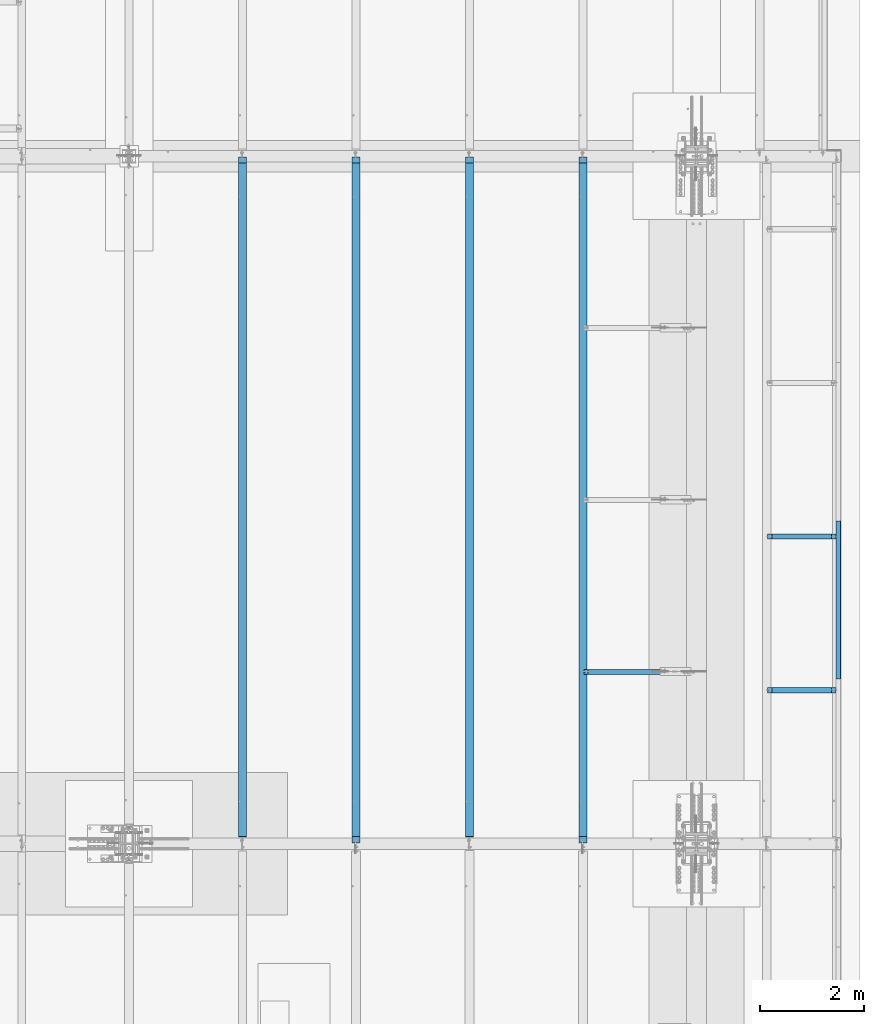
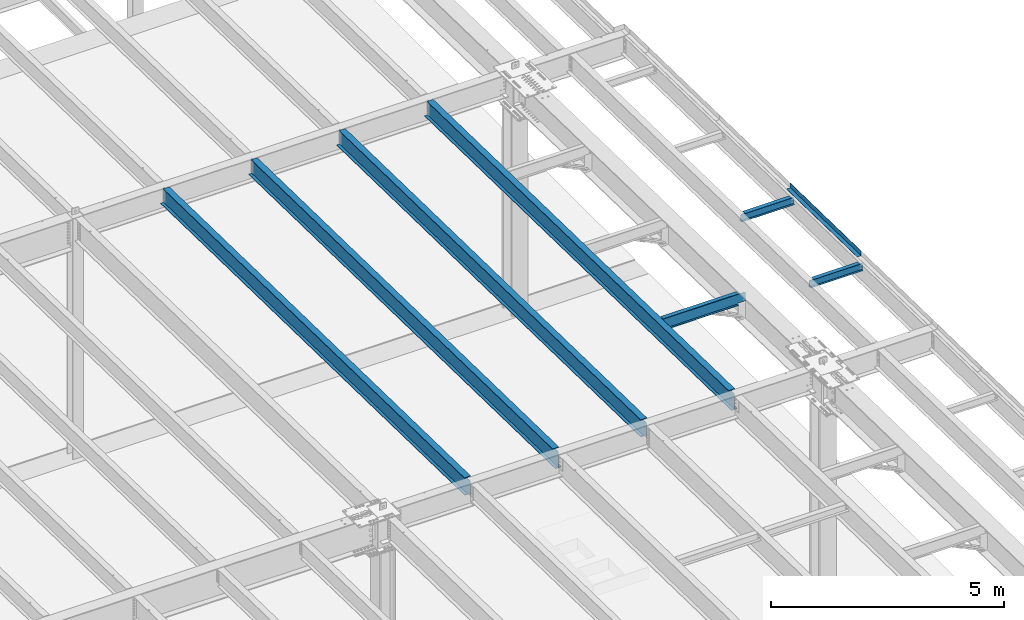
# One storey, part 1115 of 1763: 8 beams, 8 elements without a shape of their own.
"""IFC2X3 building model written with IfcOpenShell, lengths in millimetres."""

from ifc_helpers import new_model, si_unit, frame, origin_with_axes, place, context, subcontext, project, spatial, faceted_brep, material, type_object, element, aggregate, save


model = new_model("IFC2X3")

# Units and contexts
model_context = context("Model", 3, precision=1e-05, world=origin_with_axes())
body_context = subcontext(model_context, "Body", "Model", "MODEL_VIEW")
ifc_project = project(units=[si_unit("LENGTHUNIT", "METRE", prefix="MILLI"), si_unit("AREAUNIT", "SQUARE_METRE"), si_unit("VOLUMEUNIT", "CUBIC_METRE"), si_unit("MASSUNIT", "GRAM", prefix="KILO"), si_unit("TIMEUNIT", "SECOND"), si_unit("PLANEANGLEUNIT", "RADIAN"), si_unit("SOLIDANGLEUNIT", "STERADIAN"), si_unit("THERMODYNAMICTEMPERATUREUNIT", "DEGREE_CELSIUS"), si_unit("LUMINOUSINTENSITYUNIT", "LUMEN")], contexts=[model_context])

# Site, building, storey
site_placement = place(None, origin_with_axes())
site = spatial("IfcSite", under=ifc_project, at=site_placement, CompositionType="ELEMENT")
building_placement = place(site_placement, origin_with_axes())
building = spatial("IfcBuilding", under=site, at=building_placement, Name="Undefined", CompositionType="ELEMENT")
storey_placement = place(building_placement, origin_with_axes())
storey = spatial("IfcBuildingStorey", under=building, at=storey_placement, Name="Undefined", CompositionType="ELEMENT", Elevation=0.0)

# Assembly, beam
assembly_1_placement = place(storey_placement, origin_with_axes())
assembly_1 = element("IfcElementAssembly", 1, at=assembly_1_placement, inside=storey, Name="BEAM", AssemblyPlace="NOTDEFINED", PredefinedType="RIGID_FRAME")
ifc_material_1 = material(Name="STEEL/A36")
beam_type_1 = type_object("IfcBeamType", PredefinedType="NOTDEFINED")
beam_1_placement = place(assembly_1_placement, frame((-21348.1372736983, 5148.90340620207, 11813.4874748856), z_axis=(0.0, -0.999781542838788, 0.0209013539966307), x_axis=(1.0, 0.0, 0.0)))
beam_1 = element("IfcBeam", 2, at=beam_1_placement, type_object=beam_type_1, material=ifc_material_1, Name="BENT_PLATE", context=body_context, shape_type="Brep", body=[
    faceted_brep([(0.0, -3.17499999999927, -1523.99999999999), (0.0, -3.17499999999927, 1524.0), (0.0, 3.17499999999927, 1524.0), (0.0, 3.17499999999927, -1523.99999999999), (95.2499984741262, 3.17499999910251, 1523.99999999978), (95.2499984741262, 3.17500000090149, -1523.99999999977), (101.599998474125, -3.17499999909887, -1523.99999999978), (101.599999809252, -3.17500000000655, 1524.0), (95.2499984741262, 123.825003587437, 1523.99999999985), (95.2499984741262, 123.825003589236, -1523.9999999997), (101.599998474125, 123.825003587437, 1523.99999999985), (101.599998474125, 123.825003589236, -1523.9999999997)], [[[0, 1, 2, 3]], [[3, 2, 4, 5]], [[1, 0, 6, 7]], [[5, 4, 8, 9]], [[4, 2, 1, 7, 10, 8]], [[7, 6, 11, 10]], [[6, 0, 3, 5, 9, 11]], [[10, 11, 9, 8]]]),
])
aggregate(assembly_1, [beam_1])

assembly_2_placement = place(storey_placement, origin_with_axes())
assembly_2 = element("IfcElementAssembly", 3, at=assembly_2_placement, inside=storey, Name="BEAM", AssemblyPlace="NOTDEFINED", PredefinedType="RIGID_FRAME")
ifc_material_2 = material(Name="STEEL/A992")
beam_type_2 = type_object("IfcBeamType", Name="W8X10", PredefinedType="NOTDEFINED")
beam_2_placement = place(assembly_2_placement, frame((-22678.4622736983, 3413.75960699358, 11746.5740638719), z_axis=(0.0, 0.0, 1.0), x_axis=(1.0, 0.0, 0.0)))
beam_2 = element("IfcBeam", 4, at=beam_2_placement, type_object=beam_type_2, material=ifc_material_2, Name="BEAM", ObjectType="W8X10", context=body_context, shape_type="Brep", body=[
    faceted_brep([(1249.3625, -50.7999999999993, 100.012500000001), (1249.3625, -50.7999999999993, 95.25), (1249.3625, -2.38125000000036, 95.25), (1249.3625, -2.38124999999991, 83.8775014834882), (1249.3625, 2.38124999999991, 83.8775014834882), (1249.3625, 2.38125000000036, 95.25), (1249.3625, 50.7999999999993, 95.25), (1249.3625, 50.7999999999993, 100.012500000001), (1250.32922992259, -2.38124999999991, 79.0174219654418), (1250.32922992259, 2.38124999999991, 79.0174219654418), (1253.08224382306, -2.38124999999991, 74.8972454972882), (1253.08224382306, 2.38124999999991, 74.8972454972882), (1257.20242029122, -2.38124999999991, 72.1442315968106), (1257.20242029122, 2.38124999999991, 72.1442315968106), (1262.06249980926, -2.38124999999991, 71.1775016742231), (1262.06249980926, 2.38124999999991, 71.1775016742231), (1331.9125, -2.38124999999991, 71.1775016742231), (1331.9125, 2.38124999999991, 71.1775016742231), (100.012500000012, -50.7999999999993, 100.012500000001), (100.012500000012, 50.7999999999993, 100.012500000001), (100.012500000012, 50.7999999999993, 95.25), (100.012500000012, 2.38124999999854, 95.25), (100.012500000012, 2.38124999999854, 83.877501483119), (100.012500000012, -2.38124999999854, 83.877501483119), (100.012500000012, -2.38124999999854, 95.25), (100.012500000012, -50.7999999999993, 95.25), (99.0457700774241, 2.38124999999854, 79.0174219650726), (99.0457700774241, -2.38124999999854, 79.0174219650726), (96.2927561769466, 2.38124999999854, 74.8972454969189), (96.2927561769466, -2.38124999999854, 74.8972454969189), (92.1725797087929, 2.38124999999854, 72.1442315964414), (92.1725797087929, -2.38124999999854, 72.1442315964414), (87.3125001907465, 2.38124999999854, 71.1775016738538), (87.3125001907465, -2.38124999999854, 71.1775016738538), (17.4625000000015, 2.38124999999854, 71.1775016738538), (17.4625000000015, -2.38124999999854, 71.1775016738538), (17.462499935149, 2.38124999999854, -95.25), (17.4625000000015, 50.7999999999993, -95.25), (17.4625000000015, 50.7999999999993, -100.012500000001), (17.4624996160601, -50.8000000000029, -100.012500000001), (17.4624996160601, -50.8000000000029, -95.25), (17.4624999065727, -2.38124999999854, -95.25), (1331.91249999999, 2.38125000000036, -95.25), (1331.91249999999, 50.7999999999993, -95.25), (1331.91249999999, 50.7999999999993, -100.012500000001), (1331.91249999999, -50.7999999999993, -100.012500000001), (1331.91249999999, -50.7999999999993, -95.25), (1331.91249999999, -2.38125000000036, -95.25)], [[[0, 1, 2, 3, 4, 5, 6, 7]], [[8, 9, 4, 3]], [[10, 11, 9, 8]], [[12, 13, 11, 10]], [[14, 15, 13, 12]], [[16, 17, 15, 14]], [[18, 19, 20, 21, 22, 23, 24, 25]], [[23, 22, 26, 27]], [[27, 26, 28, 29]], [[29, 28, 30, 31]], [[31, 30, 32, 33]], [[33, 32, 34, 35]], [[36, 37, 38, 39, 40, 41, 35, 34]], [[37, 36, 42, 43]], [[38, 37, 43, 44]], [[39, 38, 44, 45]], [[40, 39, 45, 46]], [[41, 40, 46, 47]], [[12, 10, 8, 3, 2, 24, 23, 27, 29, 31, 33, 35, 41, 47, 16, 14]], [[25, 24, 2, 1]], [[18, 25, 1, 0]], [[19, 18, 0, 7]], [[20, 19, 7, 6]], [[21, 20, 6, 5]], [[42, 36, 34, 32, 30, 28, 26, 22, 21, 5, 4, 9, 11, 13, 15, 17]], [[47, 46, 45, 44, 43, 42, 17, 16]]]),
])
aggregate(assembly_2, [beam_2])

assembly_3_placement = place(storey_placement, origin_with_axes())
assembly_3 = element("IfcElementAssembly", 5, at=assembly_3_placement, inside=storey, Name="BEAM", AssemblyPlace="NOTDEFINED", PredefinedType="RIGID_FRAME")
beam_3_placement = place(assembly_3_placement, frame((-22678.4622736983, 6370.32164922991, 11684.7644053374), z_axis=(0.0, 0.0, 1.0), x_axis=(1.0, 0.0, 0.0)))
beam_3 = element("IfcBeam", 6, at=beam_3_placement, type_object=beam_type_2, material=ifc_material_2, Name="BEAM", ObjectType="W8X10", context=body_context, shape_type="Brep", body=[
    faceted_brep([(1249.3625, -50.7999999999993, 100.012500000001), (1249.3625, -50.7999999999993, 95.25), (1249.3625, -2.38125000000036, 95.25), (1249.3625, -2.38124999999991, 83.8775014834882), (1249.3625, 2.38124999999991, 83.8775014834882), (1249.3625, 2.38125000000036, 95.25), (1249.3625, 50.7999999999993, 95.25), (1249.3625, 50.7999999999993, 100.012500000001), (1250.32922992259, -2.38124999999991, 79.0174219654418), (1250.32922992259, 2.38124999999991, 79.0174219654418), (1253.08224382306, -2.38124999999991, 74.8972454972882), (1253.08224382306, 2.38124999999991, 74.8972454972882), (1257.20242029122, -2.38124999999991, 72.1442315968106), (1257.20242029122, 2.38124999999991, 72.1442315968106), (1262.06249980926, -2.38124999999991, 71.1775016742231), (1262.06249980926, 2.38124999999991, 71.1775016742231), (1331.9125, -2.38124999999991, 71.1775016742231), (1331.9125, 2.38124999999991, 71.1775016742231), (100.012500000012, -50.7999999999993, 100.012500000001), (100.012500000012, 50.7999999999993, 100.012500000001), (100.012500000012, 50.7999999999993, 95.25), (100.012500000012, 2.38124999999854, 95.25), (100.012500000012, 2.38124999999854, 83.877501483119), (100.012500000012, -2.38124999999854, 83.877501483119), (100.012500000012, -2.38124999999854, 95.25), (100.012500000012, -50.7999999999993, 95.25), (99.0457700774241, 2.38124999999854, 79.0174219650726), (99.0457700774241, -2.38124999999854, 79.0174219650726), (96.2927561769466, 2.38124999999854, 74.8972454969189), (96.2927561769466, -2.38124999999854, 74.8972454969189), (92.1725797087929, 2.38124999999854, 72.1442315964414), (92.1725797087929, -2.38124999999854, 72.1442315964414), (87.3125001907465, 2.38124999999854, 71.1775016738538), (87.3125001907465, -2.38124999999854, 71.1775016738538), (17.4625000000015, 2.38124999999854, 71.1775016738538), (17.4625000000015, -2.38124999999854, 71.1775016738538), (17.462499935149, 2.38124999999854, -95.25), (17.4625000000015, 50.7999999999993, -95.25), (17.4625000000015, 50.7999999999993, -100.012500000001), (17.4624996160601, -50.8000000000029, -100.012500000001), (17.4624996160601, -50.8000000000029, -95.25), (17.4624999065727, -2.38124999999854, -95.25), (1331.91249999999, 2.38125000000036, -95.25), (1331.91249999999, 50.7999999999993, -95.25), (1331.91249999999, 50.7999999999993, -100.012500000001), (1331.91249999999, -50.7999999999993, -100.012500000001), (1331.91249999999, -50.7999999999993, -95.25), (1331.91249999999, -2.38125000000036, -95.25)], [[[0, 1, 2, 3, 4, 5, 6, 7]], [[8, 9, 4, 3]], [[10, 11, 9, 8]], [[12, 13, 11, 10]], [[14, 15, 13, 12]], [[16, 17, 15, 14]], [[18, 19, 20, 21, 22, 23, 24, 25]], [[23, 22, 26, 27]], [[27, 26, 28, 29]], [[29, 28, 30, 31]], [[31, 30, 32, 33]], [[33, 32, 34, 35]], [[36, 37, 38, 39, 40, 41, 35, 34]], [[37, 36, 42, 43]], [[38, 37, 43, 44]], [[39, 38, 44, 45]], [[40, 39, 45, 46]], [[41, 40, 46, 47]], [[12, 10, 8, 3, 2, 24, 23, 27, 29, 31, 33, 35, 41, 47, 16, 14]], [[25, 24, 2, 1]], [[18, 25, 1, 0]], [[19, 18, 0, 7]], [[20, 19, 7, 6]], [[21, 20, 6, 5]], [[42, 36, 34, 32, 30, 28, 26, 22, 21, 5, 4, 9, 11, 13, 15, 17]], [[47, 46, 45, 44, 43, 42, 17, 16]]]),
])
aggregate(assembly_3, [beam_3])

assembly_4_placement = place(storey_placement, origin_with_axes())
assembly_4 = element("IfcElementAssembly", 7, at=assembly_4_placement, inside=storey, Name="BEAM", AssemblyPlace="NOTDEFINED", PredefinedType="RIGID_FRAME")
beam_type_3 = type_object("IfcBeamType", Name="W18X40", PredefinedType="NOTDEFINED")
beam_4_placement = place(assembly_4_placement, frame((-26212.2372736983, 452.455130930327, 11681.4332640109), z_axis=(0.0, 0.0209013539966291, 0.999781542838788), x_axis=(0.0, 0.999781542776098, -0.0209013569953182)))
beam_4 = element("IfcBeam", 8, at=beam_4_placement, type_object=beam_type_3, material=ifc_material_2, Name="BEAM", ObjectType="W18X40", context=body_context, shape_type="Brep", body=[
    faceted_brep([(13108.4772299965, -76.2000000000007, 227.012499995642), (13108.4772299965, -76.2000000000007, 214.312499995633), (13108.4772299965, -3.96875, 214.312499995633), (13108.4772299965, -3.96875, 201.352501414764), (13108.4772299965, 3.96875, 201.352501414764), (13108.4772299965, 3.96875, 214.312499995633), (13108.4772299965, 76.2000000000007, 214.312499995633), (13108.4772299965, 76.2000000000007, 227.012499995642), (13109.4439599191, -3.96875, 196.492421896706), (13109.4439599191, 3.96875, 196.492421896706), (13112.1969738196, -3.96875, 192.37224542854), (13112.1969738196, 3.96875, 192.37224542854), (13116.3171502878, -3.96875, 189.619231528051), (13116.3171502878, 3.96875, 189.619231528051), (13121.1772298058, -3.96875, 188.652501605458), (13121.1772298058, 3.96875, 188.652501605458), (13218.8332753145, -3.96875, 188.652501605426), (13218.8332753145, 3.96875, 188.652501605426), (137.306144927707, -76.2000000000007, 227.012500000135), (137.306144927707, 76.2000000000007, 227.012500000135), (137.306144927707, 76.2000000000007, 214.312500000124), (137.306144927707, 3.96875, 214.312500000124), (137.306144927733, 3.96875, 201.352501487894), (137.306144927733, -3.96875, 201.352501487894), (137.306144927707, -3.96875, 214.312500000124), (137.306144927707, -76.2000000000007, 214.312500000124), (136.339415005148, 3.96875, 196.492421969837), (136.339415005148, -3.96875, 196.492421969837), (133.586401104671, 3.96875, 192.372245501674), (133.586401104671, -3.96875, 192.372245501674), (129.466224636518, 3.96875, 189.619231601191), (129.466224636518, -3.96875, 189.619231601191), (124.606145118472, 3.96875, 188.652501678604), (124.606145118472, -3.96875, 188.652501678604), (19.0621902453023, 3.96875, 188.652501678604), (19.0621902453023, -3.96875, 188.652501678604), (27.4865455604509, 3.96875, -214.31250000018), (27.4865455604509, 76.2000000000007, -214.31250000018), (27.7520507831297, 76.2000000000007, -227.012500000192), (27.7520507831297, -76.2000000000007, -227.012500000192), (27.4865455604509, -76.2000000000007, -214.31250000018), (27.4865455604509, -3.96875, -214.31250000018), (13227.2576306282, 3.96875, -214.312500004748), (13227.2576306282, 76.2000000000007, -214.312500004748), (13227.5231358509, 76.2000000000007, -227.012500004759), (13227.5231358509, -76.2000000000007, -227.012500004759), (13227.2576306282, -76.2000000000007, -214.312500004748), (13227.2576306282, -3.96875, -214.312500004748)], [[[0, 1, 2, 3, 4, 5, 6, 7]], [[8, 9, 4, 3]], [[10, 11, 9, 8]], [[12, 13, 11, 10]], [[14, 15, 13, 12]], [[16, 17, 15, 14]], [[18, 19, 20, 21, 22, 23, 24, 25]], [[23, 22, 26, 27]], [[27, 26, 28, 29]], [[29, 28, 30, 31]], [[31, 30, 32, 33]], [[33, 32, 34, 35]], [[36, 37, 38, 39, 40, 41, 35, 34]], [[37, 36, 42, 43]], [[38, 37, 43, 44]], [[39, 38, 44, 45]], [[40, 39, 45, 46]], [[41, 40, 46, 47]], [[12, 10, 8, 3, 2, 24, 23, 27, 29, 31, 33, 35, 41, 47, 16, 14]], [[25, 24, 2, 1]], [[18, 25, 1, 0]], [[19, 18, 0, 7]], [[20, 19, 7, 6]], [[21, 20, 6, 5]], [[42, 36, 34, 32, 30, 28, 26, 22, 21, 5, 4, 9, 11, 13, 15, 17]], [[47, 46, 45, 44, 43, 42, 17, 16]]]),
])
aggregate(assembly_4, [beam_4])

assembly_5_placement = place(storey_placement, origin_with_axes())
assembly_5 = element("IfcElementAssembly", 9, at=assembly_5_placement, inside=storey, Name="BEAM", AssemblyPlace="NOTDEFINED", PredefinedType="RIGID_FRAME")
beam_5_placement = place(assembly_5_placement, frame((-28396.6372736983, 452.455130930327, 11681.4332640109), z_axis=(0.0, 0.0209013539966291, 0.999781542838788), x_axis=(0.0, 0.999781542776098, -0.0209013569953182)))
beam_5 = element("IfcBeam", 10, at=beam_5_placement, type_object=beam_type_3, material=ifc_material_2, Name="BEAM", ObjectType="W18X40", context=body_context, shape_type="Brep", body=[
    faceted_brep([(13108.4772299965, -76.2000000000007, 227.012499995642), (13108.4772299965, -76.2000000000007, 214.312499995633), (13108.4772299965, -3.96875, 214.312499995633), (13108.4772299965, -3.96875, 201.352501414764), (13108.4772299965, 3.96875, 201.352501414764), (13108.4772299965, 3.96875, 214.312499995633), (13108.4772299965, 76.2000000000007, 214.312499995633), (13108.4772299965, 76.2000000000007, 227.012499995642), (13109.4439599191, -3.96875, 196.492421896706), (13109.4439599191, 3.96875, 196.492421896706), (13112.1969738196, -3.96875, 192.37224542854), (13112.1969738196, 3.96875, 192.37224542854), (13116.3171502878, -3.96875, 189.619231528051), (13116.3171502878, 3.96875, 189.619231528051), (13121.1772298058, -3.96875, 188.652501605458), (13121.1772298058, 3.96875, 188.652501605458), (13218.8332753145, -3.96875, 188.652501605426), (13218.8332753145, 3.96875, 188.652501605426), (138.910239072332, -76.2000000000007, 227.012500000134), (138.910239072332, 76.2000000000007, 227.012500000134), (138.910239072332, 76.2000000000007, 214.312500000124), (138.910239072332, 3.96875, 214.312500000124), (138.910239072357, 3.96875, 201.612499809413), (138.910239072357, -3.96875, 201.612499809413), (138.910239072332, -3.96875, 214.312500000124), (138.910239072332, -76.2000000000007, 214.312500000124), (137.943509149772, 3.96875, 196.752420291354), (137.943509149772, -3.96875, 196.752420291354), (135.190495249296, 3.96875, 192.632243823193), (135.190495249296, -3.96875, 192.632243823193), (131.070318781143, 3.96875, 189.87922992271), (131.070318781143, -3.96875, 189.87922992271), (126.210239263096, 3.96875, 188.912500000122), (126.210239263096, -3.96875, 188.912500000122), (19.0567547404006, 3.96875, 188.912500000122), (19.0567547404006, -3.96875, 188.912500000122), (27.2210403377843, 3.96875, -201.612500000751), (27.2210403377843, -3.96875, -201.612500000751), (132.560239263263, 3.96875, -201.612500000885), (132.560239263263, -3.96875, -201.612500000885), (137.420318781309, 3.96875, -202.57922992348), (137.420318781309, -3.96875, -202.57922992348), (141.540495249464, 3.96875, -205.332243823967), (141.540495249464, -3.96875, -205.332243823967), (144.293509149943, 3.96875, -209.452420292133), (144.293509149943, -3.96875, -209.452420292133), (145.260239072533, 3.96875, -214.31250000022), (145.260239072533, -3.96875, -214.31250000022), (13227.2576306282, 3.96875, -214.312500004748), (13227.2576306282, 76.2000000000007, -214.312500004748), (145.260239072533, 76.2000000000007, -214.31250000022), (13227.5231358509, 76.2000000000007, -227.012500004759), (145.260239072529, 76.2000000000007, -227.01250000023), (13227.5231358509, -76.2000000000007, -227.012500004759), (13227.2576306282, -76.2000000000007, -214.312500004748), (145.260239072533, -76.2000000000007, -214.31249981019), (145.260239072528, -76.2000000000007, -227.01250000023), (13227.2576306282, -3.96875, -214.312500004748)], [[[0, 1, 2, 3, 4, 5, 6, 7]], [[8, 9, 4, 3]], [[10, 11, 9, 8]], [[12, 13, 11, 10]], [[14, 15, 13, 12]], [[16, 17, 15, 14]], [[18, 19, 20, 21, 22, 23, 24, 25]], [[23, 22, 26, 27]], [[27, 26, 28, 29]], [[29, 28, 30, 31]], [[31, 30, 32, 33]], [[33, 32, 34, 35]], [[35, 34, 36, 37]], [[37, 36, 38, 39]], [[39, 38, 40, 41]], [[41, 40, 42, 43]], [[43, 42, 44, 45]], [[45, 44, 46, 47]], [[48, 49, 50, 46]], [[49, 51, 52, 50]], [[53, 54, 55, 56]], [[51, 53, 56, 52]], [[55, 47, 46, 50, 52, 56]], [[54, 57, 47, 55]], [[12, 10, 8, 3, 2, 24, 23, 27, 29, 31, 33, 35, 37, 39, 41, 43, 45, 47, 57, 16, 14]], [[25, 24, 2, 1]], [[18, 25, 1, 0]], [[19, 18, 0, 7]], [[20, 19, 7, 6]], [[21, 20, 6, 5]], [[48, 46, 44, 42, 40, 38, 36, 34, 32, 30, 28, 26, 22, 21, 5, 4, 9, 11, 13, 15, 17]], [[57, 54, 53, 51, 49, 48, 17, 16]]]),
])
aggregate(assembly_5, [beam_5])

assembly_6_placement = place(storey_placement, origin_with_axes())
assembly_6 = element("IfcElementAssembly", 11, at=assembly_6_placement, inside=storey, Name="BEAM", AssemblyPlace="NOTDEFINED", PredefinedType="RIGID_FRAME")
beam_6_placement = place(assembly_6_placement, frame((-30581.0372736983, 452.455130930327, 11681.4332640109), z_axis=(0.0, 0.0209013539966291, 0.999781542838788), x_axis=(0.0, 0.999781542776098, -0.0209013569953182)))
beam_6 = element("IfcBeam", 12, at=beam_6_placement, type_object=beam_type_3, material=ifc_material_2, Name="BEAM", ObjectType="W18X40", context=body_context, shape_type="Brep", body=[
    faceted_brep([(13108.4772299965, -76.2000000000007, 227.012499995642), (13108.4772299965, -76.2000000000007, 214.312499995633), (13108.4772299965, -3.96875, 214.312499995633), (13108.4772299965, -3.96875, 201.352501414764), (13108.4772299965, 3.96875, 201.352501414764), (13108.4772299965, 3.96875, 214.312499995633), (13108.4772299965, 76.2000000000007, 214.312499995633), (13108.4772299965, 76.2000000000007, 227.012499995642), (13109.4439599191, -3.96875, 196.492421896706), (13109.4439599191, 3.96875, 196.492421896706), (13112.1969738196, -3.96875, 192.37224542854), (13112.1969738196, 3.96875, 192.37224542854), (13116.3171502878, -3.96875, 189.619231528051), (13116.3171502878, 3.96875, 189.619231528051), (13121.1772298058, -3.96875, 188.652501605458), (13121.1772298058, 3.96875, 188.652501605458), (13218.8332753145, -3.96875, 188.652501605426), (13218.8332753145, 3.96875, 188.652501605426), (137.306144927707, -76.2000000000007, 227.012500000135), (137.306144927707, 76.2000000000007, 227.012500000135), (137.306144927707, 76.2000000000007, 214.312500000124), (137.306144927707, 3.96875, 214.312500000124), (137.306144927733, 3.96875, 201.352501487894), (137.306144927733, -3.96875, 201.352501487894), (137.306144927707, -3.96875, 214.312500000124), (137.306144927707, -76.2000000000007, 214.312500000124), (136.339415005148, 3.96875, 196.492421969837), (136.339415005148, -3.96875, 196.492421969837), (133.586401104671, 3.96875, 192.372245501674), (133.586401104671, -3.96875, 192.372245501674), (129.466224636518, 3.96875, 189.619231601191), (129.466224636518, -3.96875, 189.619231601191), (124.606145118472, 3.96875, 188.652501678604), (124.606145118472, -3.96875, 188.652501678604), (19.0621902453023, 3.96875, 188.652501678604), (19.0621902453023, -3.96875, 188.652501678604), (27.4865455604509, 3.96875, -214.31250000018), (27.4865455604509, 76.2000000000007, -214.31250000018), (27.7520507831297, 76.2000000000007, -227.012500000192), (27.7520507831297, -76.2000000000007, -227.012500000192), (27.4865455604509, -76.2000000000007, -214.31250000018), (27.4865455604509, -3.96875, -214.31250000018), (13227.2576306282, 3.96875, -214.312500004748), (13227.2576306282, 76.2000000000007, -214.312500004748), (13227.5231358509, 76.2000000000007, -227.012500004759), (13227.5231358509, -76.2000000000007, -227.012500004759), (13227.2576306282, -76.2000000000007, -214.312500004748), (13227.2576306282, -3.96875, -214.312500004748)], [[[0, 1, 2, 3, 4, 5, 6, 7]], [[8, 9, 4, 3]], [[10, 11, 9, 8]], [[12, 13, 11, 10]], [[14, 15, 13, 12]], [[16, 17, 15, 14]], [[18, 19, 20, 21, 22, 23, 24, 25]], [[23, 22, 26, 27]], [[27, 26, 28, 29]], [[29, 28, 30, 31]], [[31, 30, 32, 33]], [[33, 32, 34, 35]], [[36, 37, 38, 39, 40, 41, 35, 34]], [[37, 36, 42, 43]], [[38, 37, 43, 44]], [[39, 38, 44, 45]], [[40, 39, 45, 46]], [[41, 40, 46, 47]], [[12, 10, 8, 3, 2, 24, 23, 27, 29, 31, 33, 35, 41, 47, 16, 14]], [[25, 24, 2, 1]], [[18, 25, 1, 0]], [[19, 18, 0, 7]], [[20, 19, 7, 6]], [[21, 20, 6, 5]], [[42, 36, 34, 32, 30, 28, 26, 22, 21, 5, 4, 9, 11, 13, 15, 17]], [[47, 46, 45, 44, 43, 42, 17, 16]]]),
])
aggregate(assembly_6, [beam_6])

assembly_7_placement = place(storey_placement, origin_with_axes())
assembly_7 = element("IfcElementAssembly", 13, at=assembly_7_placement, inside=storey, Name="BEAM", AssemblyPlace="NOTDEFINED", PredefinedType="RIGID_FRAME")
beam_7_placement = place(assembly_7_placement, frame((-32765.4372736983, 452.455130930327, 11681.4332640109), z_axis=(0.0, 0.0209013539966291, 0.999781542838788), x_axis=(0.0, 0.999781542776098, -0.0209013569953182)))
beam_7 = element("IfcBeam", 14, at=beam_7_placement, type_object=beam_type_3, material=ifc_material_2, Name="BEAM", ObjectType="W18X40", context=body_context, shape_type="Brep", body=[
    faceted_brep([(13108.4772299965, -76.2000000000007, 227.012499995642), (13108.4772299965, -76.2000000000007, 214.312499995633), (13108.4772299965, -3.96875, 214.312499995633), (13108.4772299965, -3.96875, 201.352501414764), (13108.4772299965, 3.96875, 201.352501414764), (13108.4772299965, 3.96875, 214.312499995633), (13108.4772299965, 76.2000000000007, 214.312499995633), (13108.4772299965, 76.2000000000007, 227.012499995642), (13109.4439599191, -3.96875, 196.492421896706), (13109.4439599191, 3.96875, 196.492421896706), (13112.1969738196, -3.96875, 192.37224542854), (13112.1969738196, 3.96875, 192.37224542854), (13116.3171502878, -3.96875, 189.619231528051), (13116.3171502878, 3.96875, 189.619231528051), (13121.1772298058, -3.96875, 188.652501605458), (13121.1772298058, 3.96875, 188.652501605458), (13218.8332753145, -3.96875, 188.652501605426), (13218.8332753145, 3.96875, 188.652501605426), (145.260239072332, -76.2000000000007, 227.012500000134), (145.260239072332, 76.1999999999971, 227.012500000134), (145.260239072332, 76.1999999999971, 214.312500000122), (145.260239072332, 3.96875, 214.312500000122), (145.260239072357, 3.96875, 201.6124998094), (145.260239072357, -3.96875, 201.6124998094), (145.260239072332, -3.96875, 214.312500000122), (145.260239072332, -76.2000000000007, 214.312500000122), (144.293509149773, 3.96875, 196.752420291343), (144.293509149773, -3.96875, 196.752420291343), (141.540495249296, 3.96875, 192.632243823182), (141.540495249296, -3.96875, 192.632243823182), (137.420318781143, 3.96875, 189.879229922699), (137.420318781143, -3.96875, 189.879229922699), (132.560239263097, 3.96875, 188.912500000111), (132.560239263097, -3.96875, 188.912500000111), (19.0567547404006, 3.96875, 188.912500000122), (19.0567547404006, -3.96875, 188.912500000122), (27.0882877264447, 3.96875, -195.262500000734), (27.0882877264447, -3.96875, -195.262500000734), (132.56023926326, 3.96875, -195.262500000868), (132.56023926326, -3.96875, -195.262500000868), (137.420318781306, 3.96875, -196.229229923465), (137.420318781306, -3.96875, -196.229229923465), (141.540495249461, 3.96875, -198.98224382395), (141.540495249461, -3.96875, -198.98224382395), (144.293509149941, 3.96875, -203.102420292116), (144.293509149941, -3.96875, -203.102420292116), (145.26023907253, 3.96875, -207.962499810175), (145.26023907253, -3.96875, -207.962499810175), (13227.2576306282, 3.96875, -214.312500004748), (13227.2576306282, 76.2000000000007, -214.312500004748), (145.260239072533, 76.2000000000007, -214.31250000022), (145.260239072533, 3.96875, -214.31250000022), (13227.5231358509, 76.2000000000007, -227.012500004759), (145.260239072529, 76.2000000000007, -227.01250000023), (13227.5231358509, -76.2000000000007, -227.012500004759), (145.260239072528, -76.2000000000007, -227.01250000023), (13227.2576306282, -76.2000000000007, -214.312500004748), (145.260239072533, -76.2000000000007, -214.31249981019), (145.260239072533, -3.96875, -214.31250000022), (13227.2576306282, -3.96875, -214.312500004748)], [[[0, 1, 2, 3, 4, 5, 6, 7]], [[8, 9, 4, 3]], [[10, 11, 9, 8]], [[12, 13, 11, 10]], [[14, 15, 13, 12]], [[16, 17, 15, 14]], [[18, 19, 20, 21, 22, 23, 24, 25]], [[23, 22, 26, 27]], [[27, 26, 28, 29]], [[29, 28, 30, 31]], [[31, 30, 32, 33]], [[33, 32, 34, 35]], [[35, 34, 36, 37]], [[37, 36, 38, 39]], [[39, 38, 40, 41]], [[41, 40, 42, 43]], [[43, 42, 44, 45]], [[45, 44, 46, 47]], [[48, 49, 50, 51]], [[49, 52, 53, 50]], [[52, 54, 55, 53]], [[54, 56, 57, 55]], [[47, 46, 51, 50, 53, 55, 57, 58]], [[56, 59, 58, 57]], [[12, 10, 8, 3, 2, 24, 23, 27, 29, 31, 33, 35, 37, 39, 41, 43, 45, 47, 58, 59, 16, 14]], [[25, 24, 2, 1]], [[18, 25, 1, 0]], [[19, 18, 0, 7]], [[20, 19, 7, 6]], [[21, 20, 6, 5]], [[48, 51, 46, 44, 42, 40, 38, 36, 34, 32, 30, 28, 26, 22, 21, 5, 4, 9, 11, 13, 15, 17]], [[59, 56, 54, 52, 49, 48, 17, 16]]]),
])
aggregate(assembly_7, [beam_7])

assembly_8_placement = place(storey_placement, origin_with_axes())
assembly_8 = element("IfcElementAssembly", 15, at=assembly_8_placement, inside=storey, Name="BEAM", AssemblyPlace="NOTDEFINED", PredefinedType="RIGID_FRAME")
beam_type_4 = type_object("IfcBeamType", Name="W12X22", PredefinedType="NOTDEFINED")
beam_8_placement = place(assembly_8_placement, frame((-26212.2372736983, 3765.55002966673, 11683.6570603674), z_axis=(0.0, 0.0, 1.0), x_axis=(1.0, 0.0, 0.0)))
beam_8 = element("IfcBeam", 16, at=beam_8_placement, type_object=beam_type_4, material=ifc_material_2, Name="BEAM", ObjectType="W12X22", context=body_context, shape_type="Brep", body=[
    faceted_brep([(1973.26249999999, -3.17499999999927, -144.4625), (1973.26249999999, -50.7999999999993, -144.4625), (1973.26249999999, -50.7999999999993, -155.575000000001), (1973.26249999999, 50.7999999999993, -155.575000000001), (1973.26249999999, 50.7999999999993, -144.4625), (1973.26249999999, 3.17499999999927, -144.4625), (1973.26249999999, 3.17499999999927, -136.524999809046), (1973.26249999999, -3.17499999999927, -136.524999809046), (1974.22922992258, 3.17499999999927, -131.664920290999), (1974.22922992258, -3.17499999999927, -131.664920290999), (1976.98224382305, 3.17499999999927, -127.544743822846), (1976.98224382305, -3.17499999999927, -127.544743822846), (1981.10242029121, 3.17499999999927, -124.791729922368), (1981.10242029121, -3.17499999999927, -124.791729922368), (1985.96249980925, 3.17499999999927, -123.824999999781), (1985.96249980925, -3.17499999999927, -123.824999999781), (2163.76249999999, -3.17499999999927, -123.824999999781), (2163.76249999999, 3.17499999999927, -123.824999999781), (92.8687500000051, 3.17499999999927, 144.4625), (92.8687500000051, 50.7999999999993, 144.4625), (1973.26249999999, 50.7999999999993, 144.4625), (1973.26249999999, 3.17499999999927, 144.4625), (16.6687499999898, 3.17499999999927, -144.4625), (16.6687499999898, 50.7999999999993, -144.4625), (16.6687499999898, 50.7999999999993, -155.575000000001), (16.6687499999898, -50.7999999999993, -155.575000000001), (16.6687499999898, -50.7999999999993, -144.4625), (16.6687499999898, -3.17499999999927, -144.4625), (16.6687499999898, -3.17499999999927, 123.565001683279), (16.6687499999898, 3.17499999999927, 123.565001683279), (80.16875019074, -3.17499999999927, 123.565001672911), (80.16875019074, 3.17499999999927, 123.565001672911), (85.0288297087864, -3.17499999999927, 124.531731595498), (85.0288297087864, 3.17499999999927, 124.531731595498), (89.14900617694, -3.17499999999927, 127.284745495976), (89.14900617694, 3.17499999999927, 127.284745495976), (91.9020200774175, -3.17499999999927, 131.404921964129), (91.9020200774175, 3.17499999999927, 131.404921964129), (92.8687500000051, -3.17499999999927, 136.265001482176), (92.8687500000051, 3.17499999999927, 136.265001482176), (92.8687500000051, -50.7999999999993, 155.575000000001), (92.8687500000051, 50.7999999999993, 155.575000000001), (92.8687500000051, -3.17499999999927, 144.4625), (92.8687500000051, -50.7999999999993, 144.4625), (1973.26249999999, -3.17499999999927, 144.4625), (1973.26249999999, -50.7999999999993, 144.4625), (1973.26249999999, -50.7999999999993, 155.575000000001), (1973.26249999999, 50.7999999999993, 155.575000000001), (1973.26249999999, -3.17499999999927, 123.824999809485), (1973.26249999999, 3.17499999999927, 123.824999809485), (1974.22922992258, -3.17499999999927, 118.964920291439), (1974.22922992258, 3.17499999999927, 118.964920291439), (1976.98224382305, -3.17499999999927, 114.844743823285), (1976.98224382305, 3.17499999999927, 114.844743823285), (1981.10242029121, -3.17499999999927, 112.091729922808), (1981.10242029121, 3.17499999999927, 112.091729922808), (1985.96249980925, -3.17499999999927, 111.12500000022), (1985.96249980925, 3.17499999999927, 111.12500000022), (2163.76249999999, -3.17499999999927, 111.12500000022), (2163.76249999999, 3.17499999999927, 111.12500000022)], [[[0, 1, 2, 3, 4, 5, 6, 7]], [[7, 6, 8, 9]], [[9, 8, 10, 11]], [[11, 10, 12, 13]], [[13, 12, 14, 15]], [[16, 15, 14, 17]], [[18, 19, 20, 21]], [[22, 23, 24, 25, 26, 27, 28, 29]], [[30, 31, 29, 28]], [[32, 33, 31, 30]], [[34, 35, 33, 32]], [[36, 37, 35, 34]], [[38, 39, 37, 36]], [[40, 41, 19, 18, 39, 38, 42, 43]], [[43, 42, 44, 45]], [[40, 43, 45, 46]], [[41, 40, 46, 47]], [[19, 41, 47, 20]], [[46, 45, 44, 48, 49, 21, 20, 47]], [[50, 51, 49, 48]], [[52, 53, 51, 50]], [[54, 55, 53, 52]], [[56, 57, 55, 54]], [[58, 59, 57, 56]], [[59, 58, 16, 17]], [[12, 10, 8, 6, 5, 22, 29, 31, 33, 35, 37, 39, 18, 21, 49, 51, 53, 55, 57, 59, 17, 14]], [[23, 22, 5, 4]], [[24, 23, 4, 3]], [[25, 24, 3, 2]], [[26, 25, 2, 1]], [[27, 26, 1, 0]], [[58, 56, 54, 52, 50, 48, 44, 42, 38, 36, 34, 32, 30, 28, 27, 0, 7, 9, 11, 13, 15, 16]]]),
])
aggregate(assembly_8, [beam_8])

save(model, "model.ifc")
